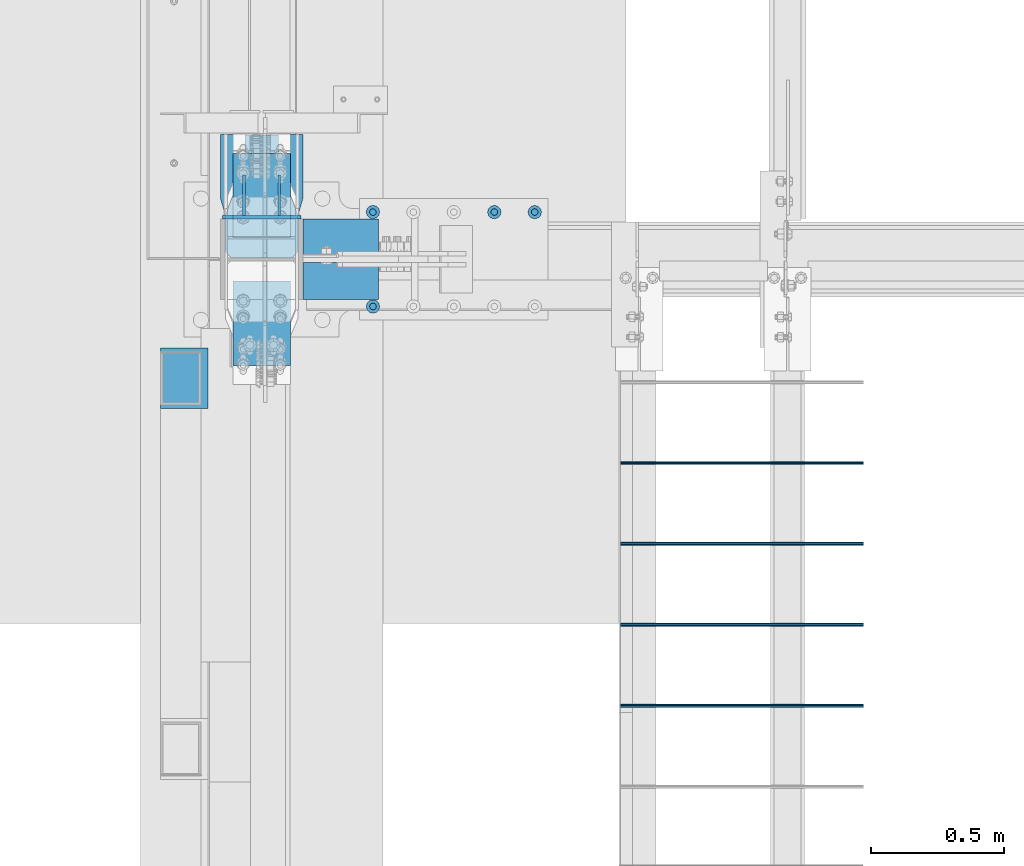
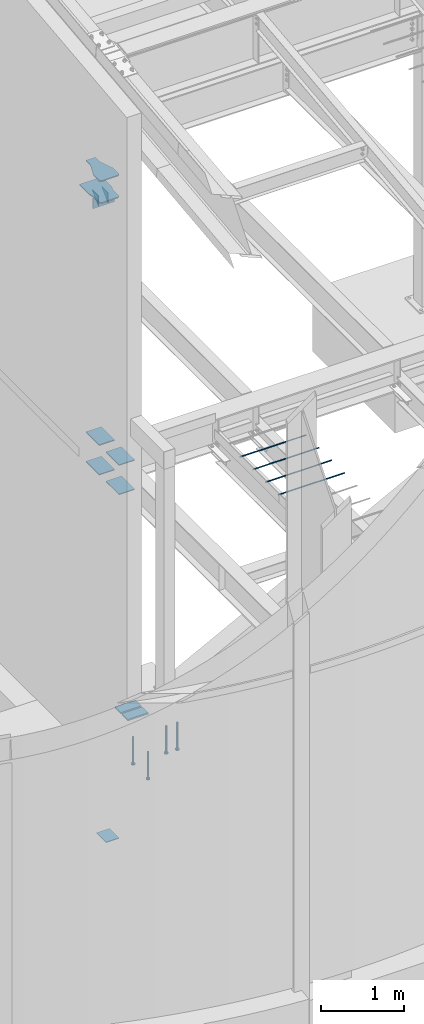
# One storey, part 805 of 1179: 20 beams, 10 elements without a shape of their own.
"""IFC2X3 building model written with IfcOpenShell, lengths in millimetres."""

from ifc_helpers import new_model, si_unit, frame, origin_with_axes, place, context, subcontext, project, spatial, faceted_brep, material, type_object, element, aggregate, save


model = new_model("IFC2X3")

# Units and contexts
model_context = context("Model", 3, precision=1e-05, world=origin_with_axes())
body_context = subcontext(model_context, "Body", "Model", "MODEL_VIEW")
ifc_project = project(units=[si_unit("LENGTHUNIT", "METRE", prefix="MILLI"), si_unit("AREAUNIT", "SQUARE_METRE"), si_unit("VOLUMEUNIT", "CUBIC_METRE"), si_unit("MASSUNIT", "GRAM", prefix="KILO"), si_unit("TIMEUNIT", "SECOND"), si_unit("PLANEANGLEUNIT", "RADIAN"), si_unit("SOLIDANGLEUNIT", "STERADIAN"), si_unit("THERMODYNAMICTEMPERATUREUNIT", "DEGREE_CELSIUS"), si_unit("LUMINOUSINTENSITYUNIT", "LUMEN")], contexts=[model_context])

# Site, building, storey
site_placement = place(None, origin_with_axes())
site = spatial("IfcSite", under=ifc_project, at=site_placement, CompositionType="ELEMENT")
building_placement = place(site_placement, origin_with_axes())
building = spatial("IfcBuilding", under=site, at=building_placement, Name="Undefined", CompositionType="ELEMENT")
storey_placement = place(building_placement, origin_with_axes())
storey = spatial("IfcBuildingStorey", under=building, at=storey_placement, Name="Undefined", CompositionType="ELEMENT", Elevation=0.0)

# Assembly, beams
assembly_1_placement = place(storey_placement, origin_with_axes())
assembly_1 = element("IfcElementAssembly", 1, at=assembly_1_placement, inside=storey, Name="COLUMN", AssemblyPlace="NOTDEFINED", PredefinedType="RIGID_FRAME")
ifc_material_1 = material(Name="STEEL/A36")
beam_type_1 = type_object("IfcBeamType", PredefinedType="NOTDEFINED")
beam_1_placement = place(assembly_1_placement, frame((284.162500000006, 5594.35, 7616.82500000912), z_axis=(0.0, 0.0, 1.0), x_axis=(1.0, 0.0, 0.0)))
beam_1 = element("IfcBeam", 2, at=beam_1_placement, type_object=beam_type_1, material=ifc_material_1, Name="PLATE", context=body_context, shape_type="Brep", body=[
    faceted_brep([(-7.27595761418343e-12, 6.35000000000036, -76.1999999999971), (0.0, 6.35000000000036, 76.2000000000044), (295.274999999994, 6.34999999999854, 76.2000000000007), (295.274999999994, 6.34999999999854, -76.2000000000007), (0.0, -6.35000000000036, 76.2000000000044), (295.274999999994, -6.34999999999854, 76.2000000000007), (7.27595761418343e-12, -6.35000000000036, -76.1999999999971), (295.274999999994, -6.34999999999854, -76.2000000000007)], [[[0, 1, 2, 3]], [[1, 4, 5, 2]], [[4, 6, 7, 5]], [[6, 0, 3, 7]], [[5, 7, 3, 2]], [[6, 4, 1, 0]]]),
])
ifc_material_2 = material(Name="STEEL/A572-GR.50")
beam_type_2 = type_object("IfcBeamType", PredefinedType="NOTDEFINED")
beam_2_placement = place(assembly_1_placement, frame((431.800000000001, 5353.84783014315, 3679.82493470237), z_axis=(-1.0, 0.0, 0.0), x_axis=(0.0, -1.0, 0.0)))
beam_2 = element("IfcBeam", 3, at=beam_2_placement, type_object=beam_type_2, material=ifc_material_2, Name="PLATE", context=body_context, shape_type="Brep", body=[
    faceted_brep([(0.0, 6.35000000000036, -107.949999999997), (0.0, 6.35000000000036, 107.949999999997), (317.5, 6.35000000000036, 107.949999999997), (317.5, 6.35000000000036, -107.949999999997), (0.0, -6.35000000000036, 107.949999999997), (317.5, -6.35000000000036, 107.949999999997), (0.0, -6.35000000000036, -107.949999999997), (317.5, -6.35000000000036, -107.949999999997)], [[[0, 1, 2, 3]], [[1, 4, 5, 2]], [[4, 6, 7, 5]], [[6, 0, 3, 7]], [[5, 7, 3, 2]], [[6, 4, 1, 0]]]),
])
beam_3_placement = place(assembly_1_placement, frame((431.800000000001, 5353.84783014315, 4108.44993470237), z_axis=(-1.0, 0.0, 0.0), x_axis=(0.0, -1.0, 0.0)))
beam_3 = element("IfcBeam", 4, at=beam_3_placement, type_object=beam_type_2, material=ifc_material_2, Name="PLATE", context=body_context, shape_type="Brep", body=[
    faceted_brep([(0.0, 6.35000000000036, -107.949999999997), (0.0, 6.35000000000036, 107.949999999997), (317.5, 6.35000000000036, 107.949999999997), (317.5, 6.35000000000036, -107.949999999997), (0.0, -6.35000000000036, 107.949999999997), (317.5, -6.35000000000036, 107.949999999997), (0.0, -6.35000000000036, -107.949999999997), (317.5, -6.35000000000036, -107.949999999997)], [[[0, 1, 2, 3]], [[1, 4, 5, 2]], [[4, 6, 7, 5]], [[6, 0, 3, 7]], [[5, 7, 3, 2]], [[6, 4, 1, 0]]]),
])
beam_4_placement = place(assembly_1_placement, frame((431.800000000001, 5517.36033014324, 3676.65), z_axis=(1.0, 0.0, 0.0), x_axis=(0.0, 1.0, 0.0)))
beam_4 = element("IfcBeam", 5, at=beam_4_placement, type_object=beam_type_2, material=ifc_material_2, Name="PLATE", context=body_context, shape_type="Brep", body=[
    faceted_brep([(0.0, 6.35000000000036, -107.949999999997), (0.0, 6.35000000000036, 107.949999999997), (316.706250012867, 6.35000000000036, 107.949999999997), (316.706250012867, 6.35000000000036, -107.949999999997), (0.0, -6.35000000000036, 107.949999999997), (316.706250012867, -6.35000000000036, 107.949999999997), (0.0, -6.35000000000036, -107.949999999997), (316.706250012867, -6.35000000000036, -107.949999999997)], [[[0, 1, 2, 3]], [[1, 4, 5, 2]], [[4, 6, 7, 5]], [[6, 0, 3, 7]], [[5, 7, 3, 2]], [[6, 4, 1, 0]]]),
])
beam_5_placement = place(assembly_1_placement, frame((431.800000000001, 5517.36033014324, 4108.44999564334), z_axis=(1.0, 0.0, 0.0), x_axis=(0.0, 1.0, 0.0)))
beam_5 = element("IfcBeam", 6, at=beam_5_placement, type_object=beam_type_2, material=ifc_material_2, Name="PLATE", context=body_context, shape_type="Brep", body=[
    faceted_brep([(0.0, 6.35000000000036, -107.949999999997), (0.0, 6.35000000000036, 107.949999999997), (316.706250012867, 6.35000000000036, 107.949999999997), (316.706250012867, 6.35000000000036, -107.949999999997), (0.0, -6.35000000000036, 107.949999999997), (316.706250012867, -6.35000000000036, 107.949999999997), (0.0, -6.35000000000036, -107.949999999997), (316.706250012867, -6.35000000000036, -107.949999999997)], [[[0, 1, 2, 3]], [[1, 4, 5, 2]], [[4, 6, 7, 5]], [[6, 0, 3, 7]], [[5, 7, 3, 2]], [[6, 4, 1, 0]]]),
])
beam_type_3 = type_object("IfcBeamType", PredefinedType="NOTDEFINED")
beam_6_placement = place(assembly_1_placement, frame((365.125000000004, 5753.10000000001, 7616.82500000912), z_axis=(0.0, 0.0, 1.0), x_axis=(0.0, -1.0, 0.0)))
beam_6 = element("IfcBeam", 7, at=beam_6_placement, type_object=beam_type_3, material=ifc_material_1, Name="PLATE", context=body_context, shape_type="Brep", body=[
    faceted_brep([(152.4, -4.76249999999709, 76.2), (152.4, -4.76249999999709, -76.2), (152.4, 4.76249999999709, -76.2), (152.4, 4.76249999999709, 76.2), (0.0, 4.76249999999982, 76.1999999999971), (0.0, -4.76249999999982, 76.1999999999971)], [[[0, 1, 2, 3]], [[3, 2, 4]], [[4, 5, 0, 3]], [[0, 5, 1]], [[4, 2, 1, 5]]]),
])
beam_7_placement = place(assembly_1_placement, frame((498.475000000002, 5753.10000000001, 7616.82500000912), z_axis=(0.0, 0.0, 1.0), x_axis=(0.0, -1.0, 0.0)))
beam_7 = element("IfcBeam", 8, at=beam_7_placement, type_object=beam_type_3, material=ifc_material_1, Name="PLATE", context=body_context, shape_type="Brep", body=[
    faceted_brep([(152.4, -4.76249999999709, 76.2), (152.4, -4.76249999999709, -76.2), (152.4, 4.76249999999709, -76.2), (152.4, 4.76249999999709, 76.2), (0.0, 4.76249999999982, 76.1999999999971), (0.0, -4.76249999999982, 76.1999999999971)], [[[0, 1, 2, 3]], [[3, 2, 4]], [[4, 5, 0, 3]], [[0, 5, 1]], [[4, 2, 1, 5]]]),
])
beam_type_4 = type_object("IfcBeamType", PredefinedType="NOTDEFINED")
beam_8_placement = place(assembly_1_placement, frame((431.800000000003, 5905.50000000001, 7700.96250000912), z_axis=(1.0, 0.0, 0.0), x_axis=(0.0, -1.0, 0.0)))
beam_8 = element("IfcBeam", 9, at=beam_8_placement, type_object=beam_type_4, material=ifc_material_1, Name="PLATE", context=body_context, shape_type="Brep", body=[
    faceted_brep([(442.111386299151, 7.93749999999, -136.52500076294), (464.33638629915, 7.93749999999, -114.30000076294), (464.336386283272, -7.93750000001, -114.30000076294), (442.111386283272, -7.93750000001, -136.52500076294), (442.111386283272, -7.93750000001, 136.52500076294), (464.336386283272, -7.93750000001, 114.30000076294), (464.33638629915, 7.93749999999, 114.30000076294), (442.111386299151, 7.93749999999, 136.52500076294), (240.498892386788, -7.93750000000546, -155.575), (240.498892418537, 7.93749999999454, -155.575), (303.998877159748, 7.93749999999363, -136.52500076294), (303.998877127999, -7.93750000000637, -136.52500076294), (0.0, -7.9375, -155.575000000001), (0.0, -7.9375, 155.575000000001), (0.0, 7.9375, 155.575000000001), (0.0, 7.9375, -155.575000000001), (240.498892386788, -7.93750000000546, 155.575), (240.498892418537, 7.93749999999454, 155.575), (303.998877127999, -7.93750000000637, 136.52500076294), (303.998877159748, 7.93749999999363, 136.52500076294)], [[[0, 1, 2, 3]], [[4, 5, 6, 7]], [[8, 9, 10, 11]], [[11, 10, 0, 3]], [[12, 13, 14, 15]], [[14, 13, 16, 17]], [[18, 19, 17, 16]], [[19, 18, 4, 7]], [[6, 5, 2, 1]], [[10, 9, 15, 14, 17, 19, 7, 6, 1, 0]], [[12, 15, 9, 8]], [[5, 4, 18, 16, 13, 12, 8, 11, 3, 2]]]),
])
aggregate(assembly_1, [beam_2, beam_3, beam_6, beam_7, beam_8, beam_1, beam_4, beam_5])

# Assembly, beam
assembly_2_placement = place(storey_placement, origin_with_axes())
assembly_2 = element("IfcElementAssembly", 10, at=assembly_2_placement, inside=storey, Name="PLATE", AssemblyPlace="NOTDEFINED", PredefinedType="RIGID_FRAME")
beam_type_5 = type_object("IfcBeamType", PredefinedType="NOTDEFINED")
beam_9_placement = place(assembly_2_placement, frame((431.800000000003, 5904.71391105044, 8021.63749927663), z_axis=(1.0, 0.0, 0.0), x_axis=(0.0, -1.0, 0.0)))
beam_9 = element("IfcBeam", 11, at=beam_9_placement, type_object=beam_type_5, material=ifc_material_1, Name="PLATE", context=body_context, shape_type="Brep", body=[
    faceted_brep([(441.325000105759, 7.9375, -136.525), (463.550000000005, 7.9375, -114.3), (463.550000000005, -7.9375, -114.3), (441.324999894251, -7.9375, -136.525000211508), (441.325000000005, -7.9375, 136.525), (463.550000000005, -7.9375, 114.3), (463.550000000005, 7.9375, 114.3), (441.325000000004, 7.9375, 136.525), (95.586987164671, -7.9375, 63.4999984741225), (95.586987164671, 7.9375, 63.4999984741225), (0.0, 7.9375, 63.5), (0.0, -7.9375, 63.5), (97.775035876015, -7.9375, 63.5944172169226), (97.775035876015, 7.9375, 63.5944172169226), (99.9468174368385, -7.9375, 63.8769714847617), (99.9468174368385, 7.9375, 63.8769714847617), (102.086185635511, -7.9375, 64.3455606147151), (102.086185635511, 7.9375, 64.3455606147151), (104.177235239064, -7.9375, 64.9967008589715), (104.177235239064, 7.9375, 64.9967008589715), (303.212487792969, -7.9375, 136.524999999998), (303.212487792969, 7.9375, 136.525), (0.0, -7.9375, -63.5), (0.0, 7.9375, -63.5), (95.5869871646701, 7.9375, -63.5), (95.5869871646701, -7.9375, -63.5), (97.775035876015, 7.9375, -63.5944187428001), (97.775035876015, -7.9375, -63.5944187428001), (99.9468174368385, 7.9375, -63.8769730106392), (99.9468174368385, -7.9375, -63.8769730106392), (102.086185635512, 7.9375, -64.3455621405926), (102.086185635512, -7.9375, -64.3455621405926), (104.177235239064, 7.9375, -64.9967023848491), (104.177235239064, -7.9375, -64.9967023848491), (303.212487792969, -7.9375, -136.525001525879), (303.212487792969, 7.9375, -136.525)], [[[0, 1, 2, 3]], [[4, 5, 6, 7]], [[8, 9, 10, 11]], [[12, 13, 9, 8]], [[14, 15, 13, 12]], [[16, 17, 15, 14]], [[18, 19, 17, 16]], [[20, 21, 19, 18]], [[22, 23, 24, 25]], [[25, 24, 26, 27]], [[27, 26, 28, 29]], [[29, 28, 30, 31]], [[31, 30, 32, 33]], [[34, 33, 32, 35]], [[34, 35, 0, 3]], [[6, 5, 2, 1]], [[5, 4, 20, 18, 16, 14, 12, 8, 11, 22, 25, 27, 29, 31, 33, 34, 3, 2]], [[22, 11, 10, 23]], [[35, 32, 30, 28, 26, 24, 23, 10, 9, 13, 15, 17, 19, 21, 7, 6, 1, 0]], [[21, 20, 4, 7]]]),
])
aggregate(assembly_2, [beam_9])

assembly_3_placement = place(storey_placement, origin_with_axes())
assembly_3 = element("IfcElementAssembly", 12, at=assembly_3_placement, inside=storey, Name="PLATE", AssemblyPlace="NOTDEFINED", PredefinedType="RIGID_FRAME")
beam_type_6 = type_object("IfcBeamType", PredefinedType="NOTDEFINED")
beam_10_placement = place(assembly_3_placement, frame((587.374999999999, 5353.04986941942, 137.764866888042), z_axis=(0.0, 1.0, 0.0), x_axis=(1.0, 0.0, 0.0)))
beam_10 = element("IfcBeam", 13, at=beam_10_placement, type_object=beam_type_6, material=ifc_material_2, Name="PLATE", context=body_context, shape_type="Brep", body=[
    faceted_brep([(0.0, 12.7, -69.8500000000004), (0.0, 12.7, 69.8500000000004), (284.057255841573, 12.7, 69.8500000000004), (284.057255841573, 12.7, -69.8500000000004), (0.0, -12.7, 69.8500000000004), (284.057255841573, -12.7, 69.8500000000004), (0.0, -12.7, -69.8500000000004), (284.057255841573, -12.7, -69.8500000000004)], [[[0, 1, 2, 3]], [[1, 4, 5, 2]], [[4, 6, 7, 5]], [[6, 0, 3, 7]], [[5, 7, 3, 2]], [[6, 4, 1, 0]]]),
])
aggregate(assembly_3, [beam_10])

assembly_4_placement = place(storey_placement, origin_with_axes())
assembly_4 = element("IfcElementAssembly", 14, at=assembly_4_placement, inside=storey, Name="PLATE", AssemblyPlace="NOTDEFINED", PredefinedType="RIGID_FRAME")
beam_11_placement = place(assembly_4_placement, frame((587.374999999999, 5518.15013058058, 137.764866888042), z_axis=(0.0, -1.0, 0.0), x_axis=(1.0, 0.0, 0.0)))
beam_11 = element("IfcBeam", 15, at=beam_11_placement, type_object=beam_type_6, material=ifc_material_2, Name="PLATE", context=body_context, shape_type="Brep", body=[
    faceted_brep([(0.0, 12.7, -69.8500000000004), (0.0, 12.7, 69.8500000000004), (284.057255841573, 12.7, 69.8500000000004), (284.057255841573, 12.7, -69.8500000000004), (0.0, -12.7, 69.8500000000004), (284.057255841573, -12.7, 69.8500000000004), (0.0, -12.7, -69.8500000000004), (284.057255841573, -12.7, -69.8500000000004)], [[[0, 1, 2, 3]], [[1, 4, 5, 2]], [[4, 6, 7, 5]], [[6, 0, 3, 7]], [[5, 7, 3, 2]], [[6, 4, 1, 0]]]),
])
aggregate(assembly_4, [beam_11])

assembly_5_placement = place(storey_placement, origin_with_axes())
assembly_5 = element("IfcElementAssembly", 16, at=assembly_5_placement, inside=storey, Name="#4 DOWEL", AssemblyPlace="NOTDEFINED", PredefinedType="NOTDEFINED")
ifc_material_3 = material(Name="REBAR/A615-40")
beam_type_7 = type_object("IfcBeamType", Name="#4 DOWEL", PredefinedType="NOTDEFINED")
beam_12_placement = place(assembly_5_placement, frame((1784.35000076294, 4668.14259468122, 3943.35000610352), z_axis=(0.0, 1.0, 0.0), x_axis=(1.0, 0.0, 0.0)))
beam_12 = element("IfcBeam", 17, at=beam_12_placement, type_object=beam_type_7, material=ifc_material_3, Name="#4 DOWEL", ObjectType="#4 DOWEL", context=body_context, shape_type="Brep", body=[
    faceted_brep([(0.0, -6.34999999999854, 0.0), (0.0, -4.49012806053361, -4.49012806053452), (914.399999999994, -4.49012806053452, -4.49012806042992), (914.399999999994, -6.34999999999991, 1.0550138540566e-10), (0.0, 0.0, -6.34999999999991), (914.399999999994, 0.0, -6.34999999989668), (0.0, 4.49012806053361, -4.49012806053452), (914.399999999994, 4.49012806053452, -4.49012806042992), (0.0, 6.34999999999854, 0.0), (914.399999999994, 6.34999999999991, 1.0550138540566e-10), (0.0, 4.49012806053361, 4.49012806053452), (914.399999999995, 4.49012806053452, 4.49012806064184), (0.0, 0.0, 6.34999999999991), (914.399999999995, 0.0, 6.35000000010768), (0.0, -4.49012806053361, 4.49012806053452), (914.399999999995, -4.49012806053452, 4.49012806064184)], [[[0, 1, 2, 3]], [[1, 4, 5, 2]], [[4, 6, 7, 5]], [[6, 8, 9, 7]], [[8, 10, 11, 9]], [[10, 12, 13, 11]], [[12, 14, 15, 13]], [[14, 0, 3, 15]], [[5, 7, 9, 11, 13, 15, 3, 2]], [[14, 12, 10, 8, 6, 4, 1, 0]]]),
])
aggregate(assembly_5, [beam_12])

assembly_6_placement = place(storey_placement, origin_with_axes())
assembly_6 = element("IfcElementAssembly", 18, at=assembly_6_placement, inside=storey, Name="#4 DOWEL", AssemblyPlace="NOTDEFINED", PredefinedType="NOTDEFINED")
beam_13_placement = place(assembly_6_placement, frame((1784.35000076294, 4363.34259468122, 3943.35000610352), z_axis=(0.0, 1.0, 0.0), x_axis=(1.0, 0.0, 0.0)))
beam_13 = element("IfcBeam", 19, at=beam_13_placement, type_object=beam_type_7, material=ifc_material_3, Name="#4 DOWEL", ObjectType="#4 DOWEL", context=body_context, shape_type="Brep", body=[
    faceted_brep([(0.0, -6.34999999999854, 0.0), (0.0, -4.49012806053361, -4.49012806053452), (914.399999999994, -4.49012806053452, -4.49012806042992), (914.399999999994, -6.34999999999991, 1.0550138540566e-10), (0.0, 0.0, -6.34999999999991), (914.399999999994, 0.0, -6.34999999989668), (0.0, 4.49012806053361, -4.49012806053452), (914.399999999994, 4.49012806053452, -4.49012806042992), (0.0, 6.34999999999854, 0.0), (914.399999999994, 6.34999999999991, 1.0550138540566e-10), (0.0, 4.49012806053361, 4.49012806053452), (914.399999999995, 4.49012806053452, 4.49012806064184), (0.0, 0.0, 6.34999999999991), (914.399999999995, 0.0, 6.35000000010768), (0.0, -4.49012806053361, 4.49012806053452), (914.399999999995, -4.49012806053452, 4.49012806064184)], [[[0, 1, 2, 3]], [[1, 4, 5, 2]], [[4, 6, 7, 5]], [[6, 8, 9, 7]], [[8, 10, 11, 9]], [[10, 12, 13, 11]], [[12, 14, 15, 13]], [[14, 0, 3, 15]], [[5, 7, 9, 11, 13, 15, 3, 2]], [[14, 12, 10, 8, 6, 4, 1, 0]]]),
])
aggregate(assembly_6, [beam_13])

assembly_7_placement = place(storey_placement, origin_with_axes())
assembly_7 = element("IfcElementAssembly", 20, at=assembly_7_placement, inside=storey, Name="#4 DOWEL", AssemblyPlace="NOTDEFINED", PredefinedType="NOTDEFINED")
beam_14_placement = place(assembly_7_placement, frame((1784.35000076294, 4058.54259468122, 3943.35000610352), z_axis=(0.0, 1.0, 0.0), x_axis=(1.0, 0.0, 0.0)))
beam_14 = element("IfcBeam", 21, at=beam_14_placement, type_object=beam_type_7, material=ifc_material_3, Name="#4 DOWEL", ObjectType="#4 DOWEL", context=body_context, shape_type="Brep", body=[
    faceted_brep([(0.0, -6.34999999999854, 0.0), (0.0, -4.49012806053361, -4.49012806053452), (914.399999999994, -4.49012806053452, -4.49012806042992), (914.399999999994, -6.34999999999991, 1.0550138540566e-10), (0.0, 0.0, -6.34999999999991), (914.399999999994, 0.0, -6.34999999989668), (0.0, 4.49012806053361, -4.49012806053452), (914.399999999994, 4.49012806053452, -4.49012806042992), (0.0, 6.34999999999854, 0.0), (914.399999999994, 6.34999999999991, 1.0550138540566e-10), (0.0, 4.49012806053361, 4.49012806053452), (914.399999999995, 4.49012806053452, 4.49012806064184), (0.0, 0.0, 6.34999999999991), (914.399999999995, 0.0, 6.35000000010768), (0.0, -4.49012806053361, 4.49012806053452), (914.399999999995, -4.49012806053452, 4.49012806064184)], [[[0, 1, 2, 3]], [[1, 4, 5, 2]], [[4, 6, 7, 5]], [[6, 8, 9, 7]], [[8, 10, 11, 9]], [[10, 12, 13, 11]], [[12, 14, 15, 13]], [[14, 0, 3, 15]], [[5, 7, 9, 11, 13, 15, 3, 2]], [[14, 12, 10, 8, 6, 4, 1, 0]]]),
])
aggregate(assembly_7, [beam_14])

assembly_8_placement = place(storey_placement, origin_with_axes())
assembly_8 = element("IfcElementAssembly", 22, at=assembly_8_placement, inside=storey, Name="#4 DOWEL", AssemblyPlace="NOTDEFINED", PredefinedType="NOTDEFINED")
beam_15_placement = place(assembly_8_placement, frame((1784.35000076294, 3753.74259468122, 3943.35000610352), z_axis=(0.0, 1.0, 0.0), x_axis=(1.0, 0.0, 0.0)))
beam_15 = element("IfcBeam", 23, at=beam_15_placement, type_object=beam_type_7, material=ifc_material_3, Name="#4 DOWEL", ObjectType="#4 DOWEL", context=body_context, shape_type="Brep", body=[
    faceted_brep([(0.0, -6.34999999999854, 0.0), (0.0, -4.49012806053361, -4.49012806053452), (914.399999999994, -4.49012806053452, -4.49012806042992), (914.399999999994, -6.34999999999991, 1.0550138540566e-10), (0.0, 0.0, -6.34999999999991), (914.399999999994, 0.0, -6.34999999989668), (0.0, 4.49012806053361, -4.49012806053452), (914.399999999994, 4.49012806053452, -4.49012806042992), (0.0, 6.34999999999854, 0.0), (914.399999999994, 6.34999999999991, 1.0550138540566e-10), (0.0, 4.49012806053361, 4.49012806053452), (914.399999999995, 4.49012806053452, 4.49012806064184), (0.0, 0.0, 6.34999999999991), (914.399999999995, 0.0, 6.35000000010768), (0.0, -4.49012806053361, 4.49012806053452), (914.399999999995, -4.49012806053452, 4.49012806064184)], [[[0, 1, 2, 3]], [[1, 4, 5, 2]], [[4, 6, 7, 5]], [[6, 8, 9, 7]], [[8, 10, 11, 9]], [[10, 12, 13, 11]], [[12, 14, 15, 13]], [[14, 0, 3, 15]], [[5, 7, 9, 11, 13, 15, 3, 2]], [[14, 12, 10, 8, 6, 4, 1, 0]]]),
])
aggregate(assembly_8, [beam_15])

# Assembly, beams
assembly_9_placement = place(storey_placement, origin_with_axes())
assembly_9 = element("IfcElementAssembly", 24, at=assembly_9_placement, inside=storey, Name="EMBED_PLATE", AssemblyPlace="NOTDEFINED", PredefinedType="RIGID_FRAME")
ifc_material_4 = material(Name="STEEL/A108")
beam_type_8 = type_object("IfcBeamType", Name="STUD_1-DIA", PredefinedType="NOTDEFINED")
beam_16_placement = place(assembly_9_placement, frame((850.900000000003, 5613.4, -393.700000000007), z_axis=(1.0, 0.0, 0.0), x_axis=(0.0, 0.0, -1.0)))
beam_16 = element("IfcBeam", 25, at=beam_16_placement, type_object=beam_type_8, material=ifc_material_4, Name="STUD", ObjectType="STUD_1-DIA", context=body_context, shape_type="Brep", body=[
    faceted_brep([(0.0, -12.7, 0.0), (0.0, -11.0, -6.34999990463257), (382.016, -11.0, -6.34999990463257), (382.016, -12.6999998092651, 0.0), (0.0, -6.34999990463257, -11.0), (382.016, -6.34999990463257, -11.0), (0.0, 0.0, -12.6999998092651), (382.016, 0.0, -12.6999998092651), (0.0, 6.34999990463257, -11.0), (382.016, 6.34999990463257, -11.0), (0.0, 11.0, -6.34999990463257), (382.016, 11.0, -6.34999990463257), (0.0, 12.7, 0.0), (382.016, 12.6999998092651, 0.0), (0.0, 11.0, 6.34999990463257), (382.016, 11.0, 6.34999990463257), (0.0, 6.34999990463257, 11.0), (382.016, 6.34999990463257, 11.0), (0.0, 0.0, 12.6999998092651), (382.016, 0.0, 12.6999998092651), (0.0, -6.34999990463257, 11.0), (382.016, -6.34999990463257, 11.0), (0.0, -11.0, 6.34999990463257), (382.016, -11.0, 6.34999990463257), (386.08, -22.0, -12.6999998092651), (386.08, -25.3999996185303, 0.0), (386.08, -12.6999998092651, -22.0), (386.08, 0.0, -25.3999996185303), (386.08, 12.6999998092651, -22.0), (386.08, 22.0, -12.6999998092651), (386.08, 25.3999996185303, 0.0), (386.08, 22.0, 12.6999998092651), (386.08, 12.6999998092651, 22.0), (386.08, 0.0, 25.3999996185303), (386.08, -12.6999998092651, 22.0), (386.08, -22.0, 12.6999998092651), (406.4, -22.0, -12.6999998092651), (406.4, -25.3999996185303, 0.0), (406.4, -12.6999998092651, -22.0), (406.4, 0.0, -25.3999996185303), (406.4, 12.6999998092651, -22.0), (406.4, 22.0, -12.6999998092651), (406.4, 25.3999996185303, 0.0), (406.4, 22.0, 12.6999998092651), (406.4, 12.6999998092651, 22.0), (406.4, 0.0, 25.3999996185303), (406.4, -12.6999998092651, 22.0), (406.4, -22.0, 12.6999998092651)], [[[0, 1, 2, 3]], [[1, 4, 5, 2]], [[4, 6, 7, 5]], [[6, 8, 9, 7]], [[8, 10, 11, 9]], [[10, 12, 13, 11]], [[12, 14, 15, 13]], [[14, 16, 17, 15]], [[16, 18, 19, 17]], [[18, 20, 21, 19]], [[20, 22, 23, 21]], [[22, 0, 3, 23]], [[22, 20, 18, 16, 14, 12, 10, 8, 6, 4, 1, 0]], [[3, 2, 24, 25]], [[2, 5, 26, 24]], [[5, 7, 27, 26]], [[7, 9, 28, 27]], [[9, 11, 29, 28]], [[11, 13, 30, 29]], [[13, 15, 31, 30]], [[15, 17, 32, 31]], [[17, 19, 33, 32]], [[19, 21, 34, 33]], [[21, 23, 35, 34]], [[23, 3, 25, 35]], [[25, 24, 36, 37]], [[24, 26, 38, 36]], [[26, 27, 39, 38]], [[27, 28, 40, 39]], [[28, 29, 41, 40]], [[29, 30, 42, 41]], [[30, 31, 43, 42]], [[31, 32, 44, 43]], [[32, 33, 45, 44]], [[33, 34, 46, 45]], [[34, 35, 47, 46]], [[35, 25, 37, 47]], [[38, 39, 40, 41, 42, 43, 44, 45, 46, 47, 37, 36]]]),
])
beam_17_placement = place(assembly_9_placement, frame((850.900000000003, 5257.8, -393.700000000007), z_axis=(1.0, 0.0, 0.0), x_axis=(0.0, 0.0, -1.0)))
beam_17 = element("IfcBeam", 26, at=beam_17_placement, type_object=beam_type_8, material=ifc_material_4, Name="STUD", ObjectType="STUD_1-DIA", context=body_context, shape_type="Brep", body=[
    faceted_brep([(0.0, -12.7, 0.0), (0.0, -11.0, -6.34999990463257), (382.016, -11.0, -6.34999990463257), (382.016, -12.6999998092651, 0.0), (0.0, -6.34999990463257, -11.0), (382.016, -6.34999990463257, -11.0), (0.0, 0.0, -12.6999998092651), (382.016, 0.0, -12.6999998092651), (0.0, 6.34999990463257, -11.0), (382.016, 6.34999990463257, -11.0), (0.0, 11.0, -6.34999990463257), (382.016, 11.0, -6.34999990463257), (0.0, 12.7, 0.0), (382.016, 12.6999998092651, 0.0), (0.0, 11.0, 6.34999990463257), (382.016, 11.0, 6.34999990463257), (0.0, 6.34999990463257, 11.0), (382.016, 6.34999990463257, 11.0), (0.0, 0.0, 12.6999998092651), (382.016, 0.0, 12.6999998092651), (0.0, -6.34999990463257, 11.0), (382.016, -6.34999990463257, 11.0), (0.0, -11.0, 6.34999990463257), (382.016, -11.0, 6.34999990463257), (386.08, -22.0, -12.6999998092651), (386.08, -25.3999996185303, 0.0), (386.08, -12.6999998092651, -22.0), (386.08, 0.0, -25.3999996185303), (386.08, 12.6999998092651, -22.0), (386.08, 22.0, -12.6999998092651), (386.08, 25.3999996185303, 0.0), (386.08, 22.0, 12.6999998092651), (386.08, 12.6999998092651, 22.0), (386.08, 0.0, 25.3999996185303), (386.08, -12.6999998092651, 22.0), (386.08, -22.0, 12.6999998092651), (406.4, -22.0, -12.6999998092651), (406.4, -25.3999996185303, 0.0), (406.4, -12.6999998092651, -22.0), (406.4, 0.0, -25.3999996185303), (406.4, 12.6999998092651, -22.0), (406.4, 22.0, -12.6999998092651), (406.4, 25.3999996185303, 0.0), (406.4, 22.0, 12.6999998092651), (406.4, 12.6999998092651, 22.0), (406.4, 0.0, 25.3999996185303), (406.4, -12.6999998092651, 22.0), (406.4, -22.0, 12.6999998092651)], [[[0, 1, 2, 3]], [[1, 4, 5, 2]], [[4, 6, 7, 5]], [[6, 8, 9, 7]], [[8, 10, 11, 9]], [[10, 12, 13, 11]], [[12, 14, 15, 13]], [[14, 16, 17, 15]], [[16, 18, 19, 17]], [[18, 20, 21, 19]], [[20, 22, 23, 21]], [[22, 0, 3, 23]], [[22, 20, 18, 16, 14, 12, 10, 8, 6, 4, 1, 0]], [[3, 2, 24, 25]], [[2, 5, 26, 24]], [[5, 7, 27, 26]], [[7, 9, 28, 27]], [[9, 11, 29, 28]], [[11, 13, 30, 29]], [[13, 15, 31, 30]], [[15, 17, 32, 31]], [[17, 19, 33, 32]], [[19, 21, 34, 33]], [[21, 23, 35, 34]], [[23, 3, 25, 35]], [[25, 24, 36, 37]], [[24, 26, 38, 36]], [[26, 27, 39, 38]], [[27, 28, 40, 39]], [[28, 29, 41, 40]], [[29, 30, 42, 41]], [[30, 31, 43, 42]], [[31, 32, 44, 43]], [[32, 33, 45, 44]], [[33, 34, 46, 45]], [[34, 35, 47, 46]], [[35, 25, 37, 47]], [[38, 39, 40, 41, 42, 43, 44, 45, 46, 47, 37, 36]]]),
])
beam_18_placement = place(assembly_9_placement, frame((1460.5, 5613.4, -393.700000000007), z_axis=(1.0, 0.0, 0.0), x_axis=(0.0, 0.0, -1.0)))
beam_18 = element("IfcBeam", 27, at=beam_18_placement, type_object=beam_type_8, material=ifc_material_4, Name="STUD", ObjectType="STUD_1-DIA", context=body_context, shape_type="Brep", body=[
    faceted_brep([(0.0, -12.7, 0.0), (0.0, -11.0, -6.34999990463257), (382.016, -11.0, -6.34999990463257), (382.016, -12.6999998092651, 0.0), (0.0, -6.34999990463257, -11.0), (382.016, -6.34999990463257, -11.0), (0.0, 0.0, -12.6999998092651), (382.016, 0.0, -12.6999998092651), (0.0, 6.34999990463257, -11.0), (382.016, 6.34999990463257, -11.0), (0.0, 11.0, -6.34999990463257), (382.016, 11.0, -6.34999990463257), (0.0, 12.7, 0.0), (382.016, 12.6999998092651, 0.0), (0.0, 11.0, 6.34999990463257), (382.016, 11.0, 6.34999990463257), (0.0, 6.34999990463257, 11.0), (382.016, 6.34999990463257, 11.0), (0.0, 0.0, 12.6999998092651), (382.016, 0.0, 12.6999998092651), (0.0, -6.34999990463257, 11.0), (382.016, -6.34999990463257, 11.0), (0.0, -11.0, 6.34999990463257), (382.016, -11.0, 6.34999990463257), (386.08, -22.0, -12.6999998092651), (386.08, -25.3999996185303, 0.0), (386.08, -12.6999998092651, -22.0), (386.08, 0.0, -25.3999996185303), (386.08, 12.6999998092651, -22.0), (386.08, 22.0, -12.6999998092651), (386.08, 25.3999996185303, 0.0), (386.08, 22.0, 12.6999998092651), (386.08, 12.6999998092651, 22.0), (386.08, 0.0, 25.3999996185303), (386.08, -12.6999998092651, 22.0), (386.08, -22.0, 12.6999998092651), (406.4, -22.0, -12.6999998092651), (406.4, -25.3999996185303, 0.0), (406.4, -12.6999998092651, -22.0), (406.4, 0.0, -25.3999996185303), (406.4, 12.6999998092651, -22.0), (406.4, 22.0, -12.6999998092651), (406.4, 25.3999996185303, 0.0), (406.4, 22.0, 12.6999998092651), (406.4, 12.6999998092651, 22.0), (406.4, 0.0, 25.3999996185303), (406.4, -12.6999998092651, 22.0), (406.4, -22.0, 12.6999998092651)], [[[0, 1, 2, 3]], [[1, 4, 5, 2]], [[4, 6, 7, 5]], [[6, 8, 9, 7]], [[8, 10, 11, 9]], [[10, 12, 13, 11]], [[12, 14, 15, 13]], [[14, 16, 17, 15]], [[16, 18, 19, 17]], [[18, 20, 21, 19]], [[20, 22, 23, 21]], [[22, 0, 3, 23]], [[22, 20, 18, 16, 14, 12, 10, 8, 6, 4, 1, 0]], [[3, 2, 24, 25]], [[2, 5, 26, 24]], [[5, 7, 27, 26]], [[7, 9, 28, 27]], [[9, 11, 29, 28]], [[11, 13, 30, 29]], [[13, 15, 31, 30]], [[15, 17, 32, 31]], [[17, 19, 33, 32]], [[19, 21, 34, 33]], [[21, 23, 35, 34]], [[23, 3, 25, 35]], [[25, 24, 36, 37]], [[24, 26, 38, 36]], [[26, 27, 39, 38]], [[27, 28, 40, 39]], [[28, 29, 41, 40]], [[29, 30, 42, 41]], [[30, 31, 43, 42]], [[31, 32, 44, 43]], [[32, 33, 45, 44]], [[33, 34, 46, 45]], [[34, 35, 47, 46]], [[35, 25, 37, 47]], [[38, 39, 40, 41, 42, 43, 44, 45, 46, 47, 37, 36]]]),
])
beam_19_placement = place(assembly_9_placement, frame((1308.1, 5613.4, -393.700000000007), z_axis=(1.0, 0.0, 0.0), x_axis=(0.0, 0.0, -1.0)))
beam_19 = element("IfcBeam", 28, at=beam_19_placement, type_object=beam_type_8, material=ifc_material_4, Name="STUD", ObjectType="STUD_1-DIA", context=body_context, shape_type="Brep", body=[
    faceted_brep([(0.0, -12.7, 0.0), (0.0, -11.0, -6.34999990463257), (382.016, -11.0, -6.34999990463257), (382.016, -12.6999998092651, 0.0), (0.0, -6.34999990463257, -11.0), (382.016, -6.34999990463257, -11.0), (0.0, 0.0, -12.6999998092651), (382.016, 0.0, -12.6999998092651), (0.0, 6.34999990463257, -11.0), (382.016, 6.34999990463257, -11.0), (0.0, 11.0, -6.34999990463257), (382.016, 11.0, -6.34999990463257), (0.0, 12.7, 0.0), (382.016, 12.6999998092651, 0.0), (0.0, 11.0, 6.34999990463257), (382.016, 11.0, 6.34999990463257), (0.0, 6.34999990463257, 11.0), (382.016, 6.34999990463257, 11.0), (0.0, 0.0, 12.6999998092651), (382.016, 0.0, 12.6999998092651), (0.0, -6.34999990463257, 11.0), (382.016, -6.34999990463257, 11.0), (0.0, -11.0, 6.34999990463257), (382.016, -11.0, 6.34999990463257), (386.08, -22.0, -12.6999998092651), (386.08, -25.3999996185303, 0.0), (386.08, -12.6999998092651, -22.0), (386.08, 0.0, -25.3999996185303), (386.08, 12.6999998092651, -22.0), (386.08, 22.0, -12.6999998092651), (386.08, 25.3999996185303, 0.0), (386.08, 22.0, 12.6999998092651), (386.08, 12.6999998092651, 22.0), (386.08, 0.0, 25.3999996185303), (386.08, -12.6999998092651, 22.0), (386.08, -22.0, 12.6999998092651), (406.4, -22.0, -12.6999998092651), (406.4, -25.3999996185303, 0.0), (406.4, -12.6999998092651, -22.0), (406.4, 0.0, -25.3999996185303), (406.4, 12.6999998092651, -22.0), (406.4, 22.0, -12.6999998092651), (406.4, 25.3999996185303, 0.0), (406.4, 22.0, 12.6999998092651), (406.4, 12.6999998092651, 22.0), (406.4, 0.0, 25.3999996185303), (406.4, -12.6999998092651, 22.0), (406.4, -22.0, 12.6999998092651)], [[[0, 1, 2, 3]], [[1, 4, 5, 2]], [[4, 6, 7, 5]], [[6, 8, 9, 7]], [[8, 10, 11, 9]], [[10, 12, 13, 11]], [[12, 14, 15, 13]], [[14, 16, 17, 15]], [[16, 18, 19, 17]], [[18, 20, 21, 19]], [[20, 22, 23, 21]], [[22, 0, 3, 23]], [[22, 20, 18, 16, 14, 12, 10, 8, 6, 4, 1, 0]], [[3, 2, 24, 25]], [[2, 5, 26, 24]], [[5, 7, 27, 26]], [[7, 9, 28, 27]], [[9, 11, 29, 28]], [[11, 13, 30, 29]], [[13, 15, 31, 30]], [[15, 17, 32, 31]], [[17, 19, 33, 32]], [[19, 21, 34, 33]], [[21, 23, 35, 34]], [[23, 3, 25, 35]], [[25, 24, 36, 37]], [[24, 26, 38, 36]], [[26, 27, 39, 38]], [[27, 28, 40, 39]], [[28, 29, 41, 40]], [[29, 30, 42, 41]], [[30, 31, 43, 42]], [[31, 32, 44, 43]], [[32, 33, 45, 44]], [[33, 34, 46, 45]], [[34, 35, 47, 46]], [[35, 25, 37, 47]], [[38, 39, 40, 41, 42, 43, 44, 45, 46, 47, 37, 36]]]),
])
aggregate(assembly_9, [beam_16, beam_17, beam_18, beam_19])

# Assembly, beam
assembly_10_placement = place(storey_placement, origin_with_axes())
assembly_10 = element("IfcElementAssembly", 29, at=assembly_10_placement, inside=storey, Name="COLUMN", AssemblyPlace="NOTDEFINED", PredefinedType="RIGID_FRAME")
beam_type_9 = type_object("IfcBeamType", PredefinedType="NOTDEFINED")
beam_20_placement = place(assembly_10_placement, frame((139.7, 4873.625, -1214.4375), z_axis=(-1.0, 0.0, 0.0), x_axis=(0.0, 1.0, 0.0)))
beam_20 = element("IfcBeam", 30, at=beam_20_placement, type_object=beam_type_9, material=ifc_material_1, Name="PLATE", context=body_context, shape_type="Brep", body=[
    faceted_brep([(0.0, 4.76250000000005, -88.9), (0.0, 4.76250000000005, 88.9), (228.6, 4.76250000000005, 88.9), (228.6, 4.76250000000005, -88.9), (0.0, -4.76250000000005, 88.9), (228.6, -4.76250000000005, 88.9), (0.0, -4.76250000000005, -88.9), (228.6, -4.76250000000005, -88.9)], [[[0, 1, 2, 3]], [[1, 4, 5, 2]], [[4, 6, 7, 5]], [[6, 0, 3, 7]], [[5, 7, 3, 2]], [[6, 4, 1, 0]]]),
])
aggregate(assembly_10, [beam_20])

save(model, "model.ifc")
